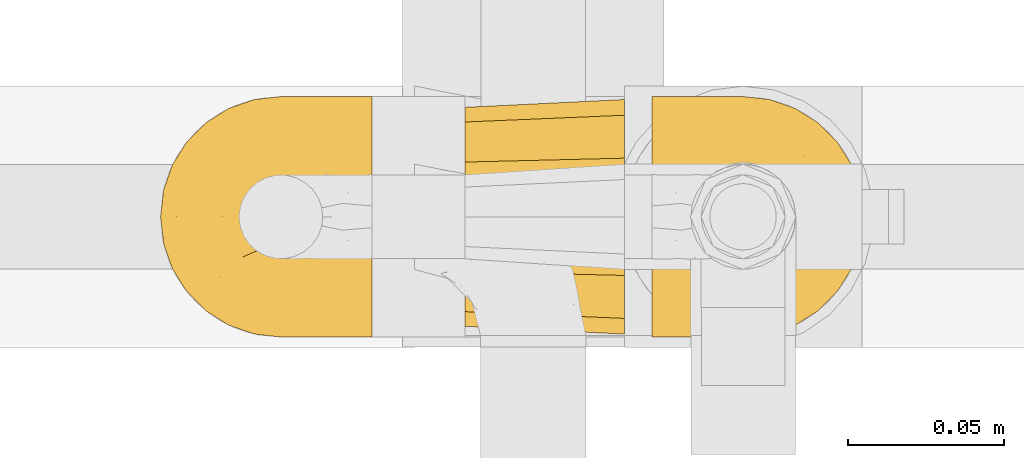
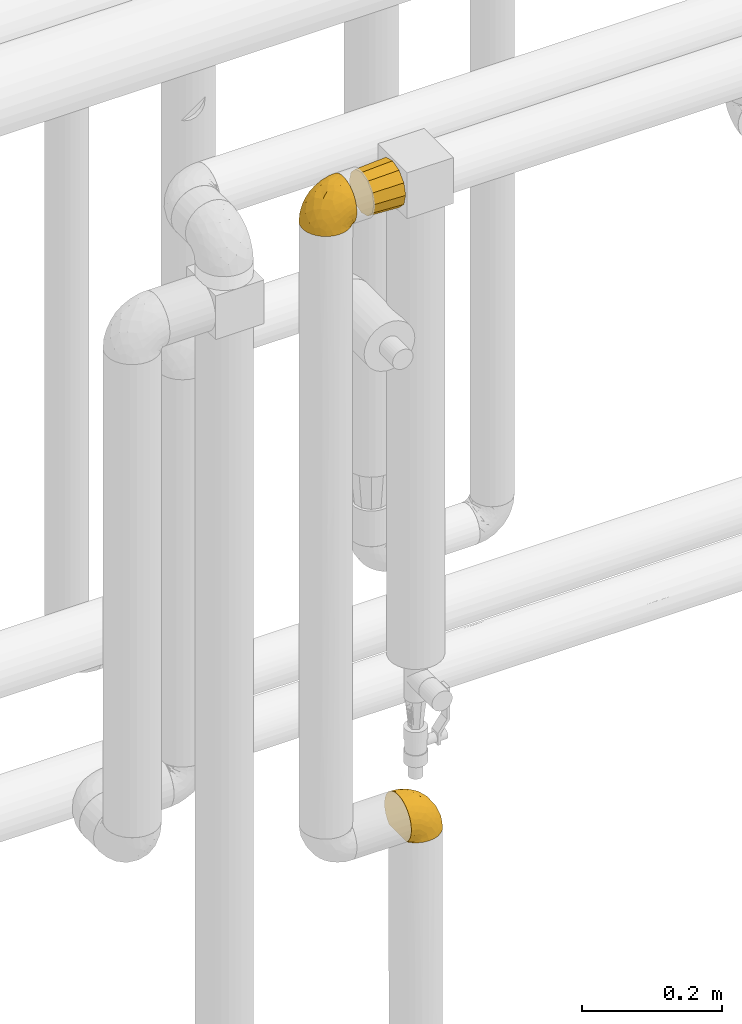
# One storey, part 442 of 827: 3 coverings.
"""IFC2X3 building model written with IfcOpenShell, lengths in millimetres."""

from ifc_helpers import new_model, entity, si_unit, converted_unit, derived_unit, direction, frame, origin, place, context, subcontext, project, spatial, faceted_brep, element, save


model = new_model("IFC2X3")

# Units and contexts
model_context = context("Model", 3, precision=0.01, world=origin(), true_north=direction((6.12303176911189e-17, 1.0)))
body_context = subcontext(model_context, "Body", "Model", "MODEL_VIEW")
ifc_project = project(units=[si_unit("LENGTHUNIT", "METRE", prefix="MILLI"), si_unit("AREAUNIT", "SQUARE_METRE"), si_unit("VOLUMEUNIT", "CUBIC_METRE"), converted_unit("PLANEANGLEUNIT", "DEGREE", entity("IfcRatioMeasure", 0.0174532925199433), si_unit("PLANEANGLEUNIT", "RADIAN"), dimensions=[0, 0, 0, 0, 0, 0, 0]), si_unit("MASSUNIT", "GRAM", prefix="KILO"), derived_unit("MASSDENSITYUNIT", [(si_unit("MASSUNIT", "GRAM", prefix="KILO"), 1), (si_unit("LENGTHUNIT", "METRE"), -3)]), derived_unit("MOMENTOFINERTIAUNIT", [(si_unit("LENGTHUNIT", "METRE"), 4)]), si_unit("TIMEUNIT", "SECOND"), si_unit("FREQUENCYUNIT", "HERTZ"), si_unit("THERMODYNAMICTEMPERATUREUNIT", "DEGREE_CELSIUS"), derived_unit("THERMALTRANSMITTANCEUNIT", [(si_unit("MASSUNIT", "GRAM", prefix="KILO"), 1), (si_unit("THERMODYNAMICTEMPERATUREUNIT", "KELVIN"), -1), (si_unit("TIMEUNIT", "SECOND"), -3)]), derived_unit("VOLUMETRICFLOWRATEUNIT", [(si_unit("LENGTHUNIT", "METRE"), 3), (si_unit("TIMEUNIT", "SECOND"), -1)]), derived_unit("MASSFLOWRATEUNIT", [(si_unit("MASSUNIT", "GRAM", prefix="KILO"), 1), (si_unit("TIMEUNIT", "SECOND"), -1)]), derived_unit("ROTATIONALFREQUENCYUNIT", [(si_unit("TIMEUNIT", "SECOND"), -1)]), si_unit("ELECTRICCURRENTUNIT", "AMPERE"), si_unit("ELECTRICVOLTAGEUNIT", "VOLT"), si_unit("POWERUNIT", "WATT"), si_unit("FORCEUNIT", "NEWTON", prefix="KILO"), si_unit("ILLUMINANCEUNIT", "LUX"), si_unit("LUMINOUSFLUXUNIT", "LUMEN"), si_unit("LUMINOUSINTENSITYUNIT", "CANDELA"), derived_unit("USERDEFINED", [(si_unit("MASSUNIT", "GRAM", prefix="KILO"), -1), (si_unit("LENGTHUNIT", "METRE"), -2), (si_unit("TIMEUNIT", "SECOND"), 3), (si_unit("LUMINOUSFLUXUNIT", "LUMEN"), 1)]), derived_unit("LINEARVELOCITYUNIT", [(si_unit("LENGTHUNIT", "METRE"), 1), (si_unit("TIMEUNIT", "SECOND"), -1)]), si_unit("PRESSUREUNIT", "PASCAL"), derived_unit("USERDEFINED", [(si_unit("LENGTHUNIT", "METRE"), -2), (si_unit("MASSUNIT", "GRAM", prefix="KILO"), 1), (si_unit("TIMEUNIT", "SECOND"), -2)]), derived_unit("LINEARFORCEUNIT", [(si_unit("MASSUNIT", "GRAM", prefix="KILO"), 1), (si_unit("LENGTHUNIT", "METRE"), 1), (si_unit("TIMEUNIT", "SECOND"), -2), (si_unit("LENGTHUNIT", "METRE"), -1)]), derived_unit("PLANARFORCEUNIT", [(si_unit("MASSUNIT", "GRAM", prefix="KILO"), 1), (si_unit("LENGTHUNIT", "METRE"), 1), (si_unit("TIMEUNIT", "SECOND"), -2), (si_unit("LENGTHUNIT", "METRE"), -2)])], contexts=[model_context])

# Site, building, storey
site_placement = place(None, origin())
site = spatial("IfcSite", under=ifc_project, at=site_placement, CompositionType="ELEMENT")
building_placement = place(site_placement, origin())
building = spatial("IfcBuilding", under=site, at=building_placement, CompositionType="ELEMENT")
storey_placement = place(building_placement, frame((0.0, 0.0, 28200.0)))
storey = spatial("IfcBuildingStorey", under=building, at=storey_placement, Name="08", CompositionType="ELEMENT", Elevation=28200.0)

# Coverings
covering_1_placement = place(storey_placement, frame((59152.59, 15404.16, 2669.3)))
element("IfcCovering", 1, at=covering_1_placement, inside=storey, Name=":ADSK_", ObjectType=":ADSK_", PredefinedType="INSULATION", context=body_context, shape_type="Brep", body=[
    faceted_brep([(23.36, 5.41, 1.6), (16.07, 9.99, 1.6), (9.98, 16.08, 1.6), (5.4, 23.37, 1.6), (2.56, 31.49, 1.6), (1.6, 40.05, 1.6), (2.56, 48.61, 1.6), (5.41, 56.73, 1.6), (9.99, 64.02, 1.6), (16.08, 70.11, 1.6), (23.37, 74.69, 1.6), (31.49, 77.53, 1.6), (40.05, 78.5, 1.6), (48.15, 77.63, 1.6), (55.88, 75.08, 1.6), (62.9, 70.97, 1.6), (68.89, 65.47, 1.6), (68.89, 63.27, 1.6), (68.89, 61.53, 1.6), (68.89, 59.57, 1.6), (68.89, 57.6, 1.6), (68.89, 55.63, 1.6), (68.89, 53.67, 1.6), (68.89, 51.7, 1.6), (68.89, 49.73, 1.6), (68.89, 47.54, 1.6), (68.89, 45.34, 1.6), (68.89, 43.15, 1.6), (68.89, 40.96, 1.6), (68.89, 38.76, 1.6), (68.89, 36.57, 1.6), (68.89, 34.37, 1.6), (68.89, 32.18, 1.6), (68.89, 29.98, 1.6), (68.89, 27.79, 1.6), (68.89, 25.6, 1.6), (68.89, 23.4, 1.6), (68.89, 21.21, 1.6), (68.89, 19.01, 1.6), (68.89, 16.82, 1.6), (68.89, 14.62, 1.6), (62.89, 9.12, 1.6), (55.86, 5.0, 1.6), (48.13, 2.46, 1.6), (40.05, 1.6, 1.6), (31.49, 2.56, 1.6), (69.15, 65.47, 1.85), (69.15, 70.97, 7.85), (69.15, 75.09, 14.87), (69.15, 77.63, 22.6), (69.15, 78.5, 30.7), (69.15, 77.19, 40.65), (69.15, 73.34, 49.92), (69.15, 67.23, 57.88), (69.15, 59.27, 63.99), (69.15, 50.0, 67.84), (69.15, 40.05, 69.15), (69.15, 30.09, 67.84), (69.15, 20.82, 63.99), (69.15, 12.86, 57.88), (69.15, 6.75, 49.92), (69.15, 2.91, 40.65), (69.15, 1.6, 30.7), (69.15, 2.46, 22.6), (69.15, 5.0, 14.87), (69.15, 9.12, 7.85), (69.15, 14.62, 1.85), (69.15, 16.82, 1.85), (69.15, 17.8, 1.85), (69.15, 19.39, 1.85), (69.15, 20.98, 1.85), (69.15, 22.57, 1.85), (69.15, 24.16, 1.85), (69.15, 25.75, 1.85), (69.15, 27.33, 1.85), (69.15, 28.92, 1.85), (69.15, 30.51, 1.85), (69.15, 32.1, 1.85), (69.15, 33.69, 1.85), (69.15, 35.28, 1.85), (69.15, 36.87, 1.85), (69.15, 38.46, 1.85), (69.15, 40.05, 1.85), (69.15, 41.63, 1.85), (69.15, 43.22, 1.85), (69.15, 44.81, 1.85), (69.15, 46.4, 1.85), (69.15, 47.99, 1.85), (69.15, 49.58, 1.85), (69.15, 51.17, 1.85), (69.15, 52.76, 1.85), (69.15, 54.72, 1.85), (69.15, 56.69, 1.85), (69.15, 58.88, 1.85), (69.15, 61.08, 1.85), (69.15, 63.27, 1.85), (68.96, 37.77, 1.77), (68.97, 36.07, 1.78), (68.97, 32.96, 1.77), (68.97, 31.36, 1.77), (68.95, 56.52, 1.76), (68.96, 54.96, 1.77), (68.98, 18.75, 1.79), (68.97, 58.07, 1.78), (68.97, 50.37, 1.78), (68.98, 23.36, 1.78), (68.97, 24.95, 1.78), (68.97, 42.43, 1.78), (68.94, 15.97, 1.74), (68.98, 51.96, 1.78), (68.98, 53.47, 1.78), (68.96, 48.63, 1.77), (68.97, 63.93, 1.78), (68.98, 40.93, 1.78), (68.98, 29.72, 1.78), (68.97, 62.4, 1.77), (68.96, 60.92, 1.77), (68.97, 17.31, 1.77), (68.97, 21.74, 1.78), (68.98, 34.56, 1.78), (68.96, 20.18, 1.77), (68.97, 14.62, 1.77), (68.94, 14.62, 1.72), (68.92, 14.62, 1.66), (68.97, 65.47, 1.77), (69.02, 65.47, 1.8), (69.08, 65.47, 1.82), (68.98, 59.5, 1.79), (68.97, 47.1, 1.78), (68.98, 45.61, 1.79), (68.97, 28.18, 1.78), (69.08, 14.62, 1.82), (69.02, 14.62, 1.8), (68.96, 26.61, 1.76), (68.92, 65.47, 1.66), (68.94, 65.47, 1.72), (68.97, 39.32, 1.78), (68.96, 44.12, 1.77), (67.02, 72.26, 9.41), (63.33, 76.57, 17.65), (64.61, 71.77, 7.41), (49.27, 78.5, 21.47), (51.4, 77.9, 15.21), (43.94, 78.5, 16.15), (61.87, 78.5, 28.75), (61.54, 75.52, 13.67), (57.95, 76.13, 12.79), (56.12, 77.81, 19.18), (63.4, 78.5, 29.16), (65.41, 72.4, 9.04), (53.1, 76.56, 7.41), (63.04, 71.77, 5.74), (61.33, 72.25, 3.72), (41.99, 78.5, 8.87), (54.6, 78.5, 26.8), (56.6, 75.75, 9.53), (41.58, 78.5, 7.34), (13.72, 50.46, 37.63), (5.82, 52.75, 17.92), (6.74, 40.05, 27.45), (58.82, 77.7, 37.01), (51.58, 77.66, 34.22), (42.09, 71.02, 45.87), (46.12, 63.45, 56.57), (55.56, 70.55, 52.31), (52.38, 75.57, 42.07), (61.54, 75.57, 44.74), (23.76, 72.61, 21.49), (20.5, 72.61, 11.02), (14.64, 67.24, 15.64), (41.77, 77.74, 26.02), (16.28, 57.43, 36.59), (49.4, 47.19, 65.49), (52.34, 54.76, 63.99), (4.3, 40.05, 15.2), (58.67, 63.45, 60.27), (25.26, 60.1, 45.25), (20.17, 63.72, 35.21), (34.7, 76.83, 22.52), (28.67, 76.34, 12.03), (8.62, 60.51, 13.32), (33.37, 72.59, 35.9), (41.35, 76.05, 33.87), (17.15, 66.15, 25.73), (12.68, 60.51, 26.34), (21.47, 51.88, 46.78), (41.11, 55.34, 59.54), (37.53, 48.67, 60.18), (30.64, 53.89, 53.93), (26.66, 46.73, 53.36), (21.38, 40.05, 49.36), (14.06, 40.05, 38.4), (55.54, 40.05, 66.44), (35.17, 63.95, 50.09), (29.04, 67.24, 41.08), (24.34, 69.62, 31.14), (29.33, 73.6, 28.19), (43.3, 40.05, 64.0), (32.34, 40.05, 56.68), (57.75, 4.52, 43.9), (49.41, 32.72, 65.46), (27.85, 27.18, 52.22), (13.7, 29.63, 37.61), (14.63, 12.86, 15.64), (8.61, 19.59, 13.31), (48.85, 9.54, 50.02), (54.13, 16.64, 59.28), (37.84, 17.48, 53.05), (23.75, 7.49, 21.48), (20.49, 7.49, 11.01), (28.66, 3.75, 12.03), (20.83, 20.75, 41.02), (55.15, 2.33, 35.39), (54.6, 1.6, 26.8), (61.87, 1.6, 28.75), (41.58, 1.6, 7.34), (57.58, 26.94, 65.81), (59.91, 9.54, 53.28), (36.94, 31.21, 59.8), (45.72, 25.33, 61.82), (5.82, 27.35, 17.91), (37.91, 8.17, 41.4), (50.18, 4.3, 40.48), (12.67, 19.59, 26.34), (49.29, 2.23, 31.68), (42.64, 2.45, 27.68), (43.94, 1.6, 16.15), (49.27, 1.6, 21.47), (19.45, 12.86, 28.05), (34.7, 3.27, 22.54), (41.99, 1.6, 8.87), (62.29, 2.29, 37.3), (29.01, 12.86, 41.07), (31.47, 6.89, 32.24), (37.18, 12.43, 47.4), (43.45, 4.1, 35.77), (63.33, 3.53, 17.65), (67.23, 6.88, 11.06), (66.07, 8.16, 8.55), (65.22, 9.02, 6.63), (61.99, 5.0, 12.77), (57.95, 3.96, 12.79), (53.09, 3.52, 7.41), (56.84, 2.4, 18.97), (61.33, 7.83, 3.72), (63.06, 8.32, 5.76), (51.41, 2.19, 15.21), (56.61, 4.34, 9.52)], [[[0, 1, 2, 3, 4, 5, 6, 7, 8, 9, 10, 11, 12, 13, 14, 15, 16, 17, 18, 19, 20, 21, 22, 23, 24, 25, 26, 27, 28, 29, 30, 31, 32, 33, 34, 35, 36, 37, 38, 39, 40, 41, 42, 43, 44, 45]], [[46, 47, 48, 49, 50, 51, 52, 53, 54, 55, 56, 57, 58, 59, 60, 61, 62, 63, 64, 65, 66, 67, 68, 69, 70, 71, 72, 73, 74, 75, 76, 77, 78, 79, 80, 81, 82, 83, 84, 85, 86, 87, 88, 89, 90, 91, 92, 93, 94, 95]], [[96, 97, 30]], [[98, 77, 99]], [[100, 101, 21]], [[69, 68, 102]], [[20, 19, 103]], [[24, 23, 104]], [[20, 103, 100]], [[72, 105, 106]], [[84, 83, 107]], [[89, 88, 104]], [[108, 67, 66]], [[109, 110, 90]], [[111, 25, 24]], [[112, 17, 16]], [[82, 113, 83]], [[109, 23, 22]], [[114, 76, 75]], [[105, 36, 106]], [[104, 111, 24]], [[18, 115, 116]], [[97, 96, 80]], [[67, 108, 117]], [[105, 71, 118]], [[31, 97, 119]], [[102, 120, 69]], [[108, 121, 122, 123, 40]], [[112, 95, 115]], [[17, 115, 18]], [[94, 116, 115]], [[117, 68, 67]], [[38, 117, 39]], [[112, 124, 125, 126, 46]], [[17, 112, 115]], [[70, 120, 118]], [[39, 117, 108]], [[120, 38, 37]], [[120, 37, 118]], [[120, 70, 69]], [[116, 94, 127]], [[128, 86, 129]], [[117, 38, 102]], [[74, 130, 75]], [[99, 33, 32]], [[115, 95, 94]], [[39, 108, 40]], [[108, 66, 131, 132, 121]], [[105, 72, 71]], [[118, 37, 36]], [[71, 70, 118]], [[35, 106, 36]], [[36, 105, 118]], [[35, 133, 106]], [[74, 73, 133]], [[106, 133, 73]], [[99, 114, 33]], [[133, 35, 34]], [[73, 72, 106]], [[95, 112, 46]], [[112, 16, 134, 135, 124]], [[130, 114, 75]], [[99, 76, 114]], [[114, 130, 33]], [[34, 33, 130]], [[78, 77, 98]], [[98, 119, 78]], [[130, 133, 34]], [[133, 130, 74]], [[79, 97, 80]], [[98, 99, 32]], [[98, 32, 31]], [[77, 76, 99]], [[97, 79, 119]], [[136, 96, 29]], [[30, 97, 31]], [[136, 29, 28]], [[81, 80, 96]], [[29, 96, 30]], [[31, 119, 98]], [[119, 79, 78]], [[96, 136, 81]], [[82, 81, 136]], [[113, 107, 83]], [[84, 107, 137]], [[107, 27, 137]], [[113, 28, 107]], [[27, 107, 28]], [[85, 84, 137]], [[137, 27, 26]], [[113, 136, 28]], [[136, 113, 82]], [[109, 89, 104]], [[86, 85, 129]], [[89, 109, 90]], [[111, 87, 128]], [[26, 129, 137]], [[88, 111, 104]], [[25, 111, 128]], [[22, 110, 109]], [[23, 109, 104]], [[110, 91, 90]], [[100, 92, 101]], [[110, 22, 101]], [[91, 110, 101]], [[116, 19, 18]], [[111, 88, 87]], [[127, 103, 19]], [[25, 128, 26]], [[86, 128, 87]], [[128, 129, 26]], [[137, 129, 85]], [[120, 102, 38]], [[117, 102, 68]], [[91, 101, 92]], [[21, 101, 22]], [[93, 92, 103]], [[100, 21, 20]], [[100, 103, 92]], [[127, 93, 103]], [[93, 127, 94]], [[116, 127, 19]], [[126, 138, 47]], [[48, 138, 139]], [[140, 125, 124]], [[141, 142, 143]], [[144, 49, 139]], [[145, 140, 146]], [[48, 139, 49]], [[139, 145, 147]], [[49, 144, 148, 50]], [[126, 125, 149]], [[14, 13, 150]], [[151, 146, 140]], [[149, 140, 145]], [[152, 151, 135]], [[152, 14, 150]], [[16, 15, 134]], [[13, 153, 150]], [[124, 151, 140]], [[141, 147, 142]], [[14, 152, 15]], [[15, 152, 134]], [[47, 46, 126]], [[139, 154, 144]], [[138, 48, 47]], [[125, 140, 149]], [[135, 134, 152]], [[146, 155, 142]], [[145, 146, 147]], [[149, 139, 138]], [[147, 141, 154]], [[147, 146, 142]], [[139, 147, 154]], [[139, 149, 145]], [[149, 138, 126]], [[155, 146, 151]], [[150, 143, 142]], [[152, 155, 151]], [[150, 142, 155]], [[13, 12, 156, 153]], [[153, 143, 150]], [[152, 150, 155]], [[151, 124, 135]], [[157, 158, 159]], [[160, 154, 161]], [[162, 163, 164]], [[165, 166, 160]], [[167, 168, 169]], [[141, 170, 161]], [[156, 12, 11]], [[158, 157, 171]], [[172, 55, 173]], [[158, 6, 174]], [[175, 54, 53]], [[52, 166, 164]], [[52, 164, 53]], [[54, 175, 173]], [[166, 52, 51]], [[176, 177, 171]], [[178, 143, 179]], [[156, 11, 179]], [[8, 7, 180]], [[169, 9, 8]], [[179, 143, 153, 156]], [[179, 11, 10]], [[168, 179, 10]], [[181, 162, 182]], [[179, 167, 178]], [[183, 184, 177]], [[183, 169, 184]], [[176, 171, 185]], [[172, 186, 187]], [[158, 7, 6]], [[159, 158, 174]], [[184, 180, 158]], [[54, 173, 55]], [[180, 169, 8]], [[188, 189, 187]], [[9, 168, 10]], [[186, 188, 187]], [[190, 157, 159, 191]], [[55, 172, 192]], [[176, 193, 194]], [[161, 170, 182]], [[162, 164, 165]], [[175, 164, 163]], [[51, 50, 148]], [[167, 195, 196]], [[178, 182, 170]], [[6, 5, 174]], [[158, 180, 7]], [[169, 180, 184]], [[169, 168, 9]], [[179, 168, 167]], [[182, 162, 165]], [[162, 194, 193]], [[161, 165, 160]], [[195, 181, 196]], [[192, 172, 197]], [[192, 56, 55]], [[189, 190, 198]], [[198, 197, 187]], [[172, 187, 197]], [[185, 189, 188]], [[198, 187, 189]], [[186, 172, 173]], [[173, 163, 186]], [[193, 186, 163]], [[176, 185, 188]], [[185, 157, 190]], [[188, 186, 193]], [[177, 176, 194]], [[188, 193, 176]], [[162, 193, 163]], [[195, 177, 194]], [[171, 177, 184]], [[181, 195, 194]], [[183, 167, 169]], [[162, 181, 194]], [[196, 182, 178]], [[158, 171, 184]], [[171, 157, 185]], [[177, 195, 183]], [[167, 183, 195]], [[182, 196, 181]], [[178, 170, 143]], [[178, 167, 196]], [[164, 175, 53]], [[173, 175, 163]], [[160, 51, 148]], [[164, 166, 165]], [[51, 160, 166]], [[160, 148, 144, 154]], [[141, 161, 154]], [[182, 165, 161]], [[190, 189, 185]], [[143, 170, 141]], [[60, 199, 61]], [[197, 200, 192]], [[201, 190, 202]], [[200, 57, 192]], [[203, 204, 2]], [[205, 206, 207]], [[208, 209, 210]], [[211, 207, 201]], [[212, 213, 214]], [[45, 215, 210]], [[216, 206, 58]], [[45, 44, 215]], [[59, 217, 60]], [[60, 217, 199]], [[0, 45, 210]], [[218, 201, 219]], [[202, 159, 220]], [[205, 221, 222]], [[223, 204, 203]], [[1, 203, 2]], [[57, 200, 216]], [[220, 3, 204]], [[220, 174, 4]], [[1, 0, 209]], [[212, 224, 213]], [[225, 226, 227]], [[228, 223, 203]], [[208, 210, 229]], [[210, 226, 229]], [[3, 220, 4]], [[58, 206, 59]], [[209, 203, 1]], [[202, 220, 223]], [[228, 203, 208]], [[202, 211, 201]], [[3, 2, 204]], [[202, 190, 191, 159]], [[210, 215, 230, 226]], [[199, 212, 231]], [[232, 233, 221]], [[233, 208, 229]], [[207, 206, 219]], [[217, 206, 205]], [[227, 224, 225]], [[233, 232, 228]], [[201, 207, 219]], [[234, 232, 221]], [[218, 219, 200]], [[202, 223, 211]], [[174, 220, 159]], [[174, 5, 4]], [[61, 231, 62]], [[220, 204, 223]], [[210, 209, 0]], [[203, 209, 208]], [[225, 233, 229]], [[224, 227, 213]], [[221, 233, 235]], [[57, 56, 192]], [[198, 218, 197]], [[200, 219, 216]], [[201, 198, 190]], [[197, 218, 200]], [[198, 201, 218]], [[206, 216, 219]], [[58, 57, 216]], [[231, 212, 214]], [[222, 212, 199]], [[228, 211, 223]], [[207, 211, 232]], [[62, 231, 214]], [[199, 231, 61]], [[233, 228, 208]], [[211, 228, 232]], [[222, 221, 235]], [[234, 205, 207]], [[206, 217, 59]], [[199, 217, 205]], [[205, 222, 199]], [[224, 222, 235]], [[222, 224, 212]], [[224, 235, 225]], [[233, 225, 235]], [[226, 225, 229]], [[205, 234, 221]], [[207, 232, 234]], [[63, 214, 236]], [[214, 213, 236]], [[214, 63, 62]], [[237, 236, 238]], [[238, 132, 131]], [[236, 237, 64]], [[239, 240, 241]], [[63, 236, 64]], [[131, 66, 65]], [[237, 131, 65]], [[242, 230, 43]], [[237, 65, 64]], [[239, 121, 132]], [[42, 242, 43]], [[241, 240, 243]], [[41, 123, 244]], [[43, 230, 215, 44]], [[244, 122, 245]], [[227, 246, 243]], [[241, 247, 245]], [[121, 239, 245]], [[41, 40, 123]], [[132, 238, 239]], [[244, 42, 41]], [[131, 237, 238]], [[240, 239, 238]], [[245, 239, 241]], [[247, 241, 246]], [[247, 244, 245]], [[238, 236, 240]], [[243, 236, 213]], [[236, 243, 240]], [[227, 226, 246]], [[243, 213, 227]], [[242, 246, 226]], [[243, 246, 241]], [[246, 242, 247]], [[244, 247, 242]], [[242, 226, 230]], [[42, 244, 242]], [[122, 244, 123]], [[122, 121, 245]]]),
])
covering_2_placement = place(storey_placement, frame((59309.77, 15404.16, 1562.35)))
element("IfcCovering", 2, at=covering_2_placement, inside=storey, Name=":ADSK_", ObjectType=":ADSK_", PredefinedType="INSULATION", context=body_context, shape_type="Brep", body=[
    faceted_brep([(47.38, 74.68, 1.6), (54.67, 70.1, 1.6), (60.76, 64.01, 1.6), (65.34, 56.72, 1.6), (68.18, 48.6, 1.6), (69.15, 40.05, 1.6), (68.18, 31.49, 1.6), (65.33, 23.36, 1.6), (60.75, 16.07, 1.6), (54.66, 9.98, 1.6), (47.37, 5.4, 1.6), (39.25, 2.56, 1.6), (30.7, 1.6, 1.6), (22.59, 2.46, 1.6), (14.86, 5.01, 1.6), (7.84, 9.13, 1.6), (1.85, 14.62, 1.6), (1.85, 16.82, 1.6), (1.85, 18.56, 1.6), (1.85, 20.52, 1.6), (1.85, 22.49, 1.6), (1.85, 24.46, 1.6), (1.85, 26.42, 1.6), (1.85, 28.39, 1.6), (1.85, 30.36, 1.6), (1.85, 32.55, 1.6), (1.85, 34.75, 1.6), (1.85, 36.94, 1.6), (1.85, 39.13, 1.6), (1.85, 41.33, 1.6), (1.85, 43.52, 1.6), (1.85, 45.72, 1.6), (1.85, 47.91, 1.6), (1.85, 50.11, 1.6), (1.85, 52.3, 1.6), (1.85, 54.49, 1.6), (1.85, 56.69, 1.6), (1.85, 58.88, 1.6), (1.85, 61.08, 1.6), (1.85, 63.27, 1.6), (1.85, 65.47, 1.6), (7.85, 70.97, 1.6), (14.88, 75.09, 1.6), (22.61, 77.64, 1.6), (30.7, 78.5, 1.6), (39.26, 77.53, 1.6), (1.6, 14.62, 1.85), (1.6, 9.12, 7.85), (1.6, 5.0, 14.87), (1.6, 2.46, 22.6), (1.6, 1.6, 30.7), (1.6, 2.91, 40.65), (1.6, 6.75, 49.92), (1.6, 12.86, 57.88), (1.6, 20.82, 63.99), (1.6, 30.09, 67.84), (1.6, 40.05, 69.15), (1.6, 50.0, 67.84), (1.6, 59.27, 63.99), (1.6, 67.23, 57.88), (1.6, 73.34, 49.92), (1.6, 77.19, 40.65), (1.6, 78.5, 30.7), (1.6, 77.63, 22.6), (1.6, 75.09, 14.87), (1.6, 70.97, 7.85), (1.6, 65.47, 1.85), (1.6, 63.27, 1.85), (1.6, 62.29, 1.85), (1.6, 60.7, 1.85), (1.6, 59.11, 1.85), (1.6, 57.52, 1.85), (1.6, 55.93, 1.85), (1.6, 54.34, 1.85), (1.6, 52.76, 1.85), (1.6, 51.17, 1.85), (1.6, 49.58, 1.85), (1.6, 47.99, 1.85), (1.6, 46.4, 1.85), (1.6, 44.81, 1.85), (1.6, 43.22, 1.85), (1.6, 41.63, 1.85), (1.6, 40.05, 1.85), (1.6, 38.46, 1.85), (1.6, 36.87, 1.85), (1.6, 35.28, 1.85), (1.6, 33.69, 1.85), (1.6, 32.1, 1.85), (1.6, 30.51, 1.85), (1.6, 28.92, 1.85), (1.6, 27.33, 1.85), (1.6, 25.37, 1.85), (1.6, 23.4, 1.85), (1.6, 21.21, 1.85), (1.6, 19.01, 1.85), (1.6, 16.82, 1.85), (1.78, 42.32, 1.77), (1.77, 44.02, 1.78), (1.78, 47.13, 1.77), (1.77, 48.74, 1.77), (1.79, 23.57, 1.76), (1.78, 25.13, 1.77), (1.76, 61.34, 1.79), (1.77, 22.02, 1.78), (1.77, 29.72, 1.78), (1.76, 56.73, 1.78), (1.77, 55.14, 1.78), (1.77, 37.66, 1.78), (1.8, 64.12, 1.74), (1.76, 28.13, 1.78), (1.77, 26.62, 1.78), (1.78, 31.46, 1.77), (1.77, 16.16, 1.78), (1.77, 39.16, 1.78), (1.76, 50.37, 1.78), (1.77, 17.69, 1.77), (1.78, 19.17, 1.77), (1.77, 62.78, 1.77), (1.77, 58.35, 1.78), (1.77, 45.53, 1.78), (1.78, 59.91, 1.77), (1.77, 65.47, 1.77), (1.8, 65.47, 1.72), (1.82, 65.47, 1.66), (1.77, 14.62, 1.77), (1.72, 14.62, 1.8), (1.66, 14.62, 1.82), (1.76, 20.59, 1.79), (1.77, 32.99, 1.78), (1.76, 34.48, 1.79), (1.77, 51.91, 1.78), (1.66, 65.47, 1.82), (1.72, 65.47, 1.8), (1.78, 53.48, 1.76), (1.82, 14.62, 1.66), (1.8, 14.62, 1.72), (1.77, 40.77, 1.78), (1.78, 35.97, 1.77), (3.72, 7.84, 9.41), (7.41, 3.53, 17.65), (6.13, 8.32, 7.41), (21.47, 1.6, 21.47), (19.34, 2.19, 15.21), (26.8, 1.6, 16.15), (8.87, 1.6, 28.75), (9.2, 4.57, 13.67), (12.79, 3.96, 12.79), (14.62, 2.28, 19.18), (7.34, 1.6, 29.16), (5.33, 7.69, 9.04), (17.64, 3.53, 7.41), (7.7, 8.32, 5.74), (9.41, 7.84, 3.72), (28.75, 1.6, 8.87), (16.15, 1.6, 26.8), (14.14, 4.34, 9.53), (29.16, 1.6, 7.34), (57.02, 29.63, 37.63), (64.92, 27.34, 17.92), (64.0, 40.05, 27.45), (11.92, 2.39, 37.01), (19.16, 2.43, 34.22), (28.65, 9.07, 45.87), (24.62, 16.64, 56.57), (15.19, 9.54, 52.31), (18.36, 4.52, 42.07), (9.2, 4.52, 44.74), (46.98, 7.49, 21.49), (50.24, 7.49, 11.02), (56.1, 12.85, 15.64), (28.97, 2.35, 26.02), (54.46, 22.66, 36.59), (21.34, 32.9, 65.49), (18.4, 25.33, 63.99), (66.44, 40.05, 15.2), (12.07, 16.64, 60.27), (45.49, 19.99, 45.25), (50.57, 16.37, 35.21), (36.04, 3.26, 22.52), (42.07, 3.75, 12.03), (62.12, 19.58, 13.32), (37.37, 7.5, 35.9), (29.39, 4.04, 33.87), (53.59, 13.94, 25.73), (58.06, 19.58, 26.34), (49.27, 28.21, 46.78), (29.63, 24.75, 59.54), (33.21, 31.42, 60.18), (40.1, 26.2, 53.93), (44.08, 33.36, 53.36), (49.36, 40.05, 49.36), (56.68, 40.05, 38.4), (15.2, 40.05, 66.44), (35.57, 16.14, 50.09), (41.7, 12.85, 41.08), (46.4, 10.47, 31.14), (41.41, 6.49, 28.19), (27.45, 40.05, 64.0), (38.4, 40.05, 56.68), (12.99, 75.57, 43.9), (21.33, 47.37, 65.46), (42.89, 52.91, 52.22), (57.04, 50.46, 37.61), (56.11, 67.23, 15.64), (62.13, 60.5, 13.31), (21.89, 70.55, 50.02), (16.62, 63.45, 59.28), (32.9, 62.61, 53.05), (46.99, 72.6, 21.48), (50.25, 72.6, 11.01), (42.08, 76.34, 12.03), (49.91, 59.34, 41.02), (15.6, 77.76, 35.39), (16.15, 78.5, 26.8), (8.87, 78.5, 28.75), (29.16, 78.5, 7.34), (13.16, 53.16, 65.81), (10.83, 70.55, 53.28), (33.8, 48.88, 59.8), (25.02, 54.76, 61.82), (64.92, 52.74, 17.91), (32.83, 71.93, 41.4), (20.56, 75.79, 40.48), (58.07, 60.5, 26.34), (21.46, 77.86, 31.68), (28.1, 77.64, 27.68), (26.8, 78.5, 16.15), (21.47, 78.5, 21.47), (51.29, 67.23, 28.05), (36.04, 76.82, 22.54), (28.75, 78.5, 8.87), (8.45, 77.8, 37.3), (41.73, 67.23, 41.07), (39.27, 73.2, 32.24), (33.56, 67.66, 47.4), (27.29, 75.99, 35.77), (7.41, 76.57, 17.65), (3.51, 73.21, 11.06), (4.68, 71.93, 8.55), (5.52, 71.07, 6.63), (8.75, 75.09, 12.77), (12.79, 76.13, 12.79), (17.65, 76.57, 7.41), (13.9, 77.69, 18.97), (9.42, 72.26, 3.72), (7.68, 71.77, 5.76), (19.33, 77.9, 15.21), (14.13, 75.75, 9.52)], [[[0, 1, 2, 3, 4, 5, 6, 7, 8, 9, 10, 11, 12, 13, 14, 15, 16, 17, 18, 19, 20, 21, 22, 23, 24, 25, 26, 27, 28, 29, 30, 31, 32, 33, 34, 35, 36, 37, 38, 39, 40, 41, 42, 43, 44, 45]], [[46, 47, 48, 49, 50, 51, 52, 53, 54, 55, 56, 57, 58, 59, 60, 61, 62, 63, 64, 65, 66, 67, 68, 69, 70, 71, 72, 73, 74, 75, 76, 77, 78, 79, 80, 81, 82, 83, 84, 85, 86, 87, 88, 89, 90, 91, 92, 93, 94, 95]], [[96, 97, 30]], [[98, 77, 99]], [[100, 101, 21]], [[69, 68, 102]], [[20, 19, 103]], [[24, 23, 104]], [[20, 103, 100]], [[72, 105, 106]], [[84, 83, 107]], [[89, 88, 104]], [[108, 67, 66]], [[109, 110, 90]], [[111, 25, 24]], [[112, 17, 16]], [[82, 113, 83]], [[109, 23, 22]], [[114, 76, 75]], [[105, 36, 106]], [[104, 111, 24]], [[18, 115, 116]], [[97, 96, 80]], [[67, 108, 117]], [[105, 71, 118]], [[31, 97, 119]], [[102, 120, 69]], [[108, 121, 122, 123, 40]], [[112, 95, 115]], [[17, 115, 18]], [[94, 116, 115]], [[117, 68, 67]], [[38, 117, 39]], [[112, 124, 125, 126, 46]], [[17, 112, 115]], [[70, 120, 118]], [[39, 117, 108]], [[120, 38, 37]], [[120, 37, 118]], [[120, 70, 69]], [[116, 94, 127]], [[128, 86, 129]], [[117, 38, 102]], [[74, 130, 75]], [[99, 33, 32]], [[115, 95, 94]], [[39, 108, 40]], [[108, 66, 131, 132, 121]], [[105, 72, 71]], [[118, 37, 36]], [[71, 70, 118]], [[35, 106, 36]], [[36, 105, 118]], [[35, 133, 106]], [[74, 73, 133]], [[106, 133, 73]], [[99, 114, 33]], [[133, 35, 34]], [[73, 72, 106]], [[95, 112, 46]], [[112, 16, 134, 135, 124]], [[130, 114, 75]], [[99, 76, 114]], [[114, 130, 33]], [[34, 33, 130]], [[78, 77, 98]], [[98, 119, 78]], [[130, 133, 34]], [[133, 130, 74]], [[79, 97, 80]], [[98, 99, 32]], [[98, 32, 31]], [[77, 76, 99]], [[97, 79, 119]], [[136, 96, 29]], [[30, 97, 31]], [[136, 29, 28]], [[81, 80, 96]], [[29, 96, 30]], [[31, 119, 98]], [[119, 79, 78]], [[96, 136, 81]], [[82, 81, 136]], [[113, 107, 83]], [[84, 107, 137]], [[107, 27, 137]], [[113, 28, 107]], [[27, 107, 28]], [[85, 84, 137]], [[137, 27, 26]], [[113, 136, 28]], [[136, 113, 82]], [[109, 89, 104]], [[86, 85, 129]], [[89, 109, 90]], [[111, 87, 128]], [[26, 129, 137]], [[88, 111, 104]], [[25, 111, 128]], [[22, 110, 109]], [[23, 109, 104]], [[110, 91, 90]], [[100, 92, 101]], [[110, 22, 101]], [[91, 110, 101]], [[116, 19, 18]], [[111, 88, 87]], [[127, 103, 19]], [[25, 128, 26]], [[86, 128, 87]], [[128, 129, 26]], [[137, 129, 85]], [[120, 102, 38]], [[117, 102, 68]], [[91, 101, 92]], [[21, 101, 22]], [[93, 92, 103]], [[100, 21, 20]], [[100, 103, 92]], [[127, 93, 103]], [[93, 127, 94]], [[116, 127, 19]], [[126, 138, 47]], [[48, 138, 139]], [[140, 125, 124]], [[141, 142, 143]], [[144, 49, 139]], [[145, 140, 146]], [[48, 139, 49]], [[139, 145, 147]], [[49, 144, 148, 50]], [[126, 125, 149]], [[14, 13, 150]], [[151, 146, 140]], [[149, 140, 145]], [[152, 151, 135]], [[152, 14, 150]], [[16, 15, 134]], [[13, 153, 150]], [[124, 151, 140]], [[141, 147, 142]], [[14, 152, 15]], [[15, 152, 134]], [[47, 46, 126]], [[139, 154, 144]], [[138, 48, 47]], [[125, 140, 149]], [[135, 134, 152]], [[146, 155, 142]], [[145, 146, 147]], [[149, 139, 138]], [[147, 141, 154]], [[147, 146, 142]], [[139, 147, 154]], [[139, 149, 145]], [[149, 138, 126]], [[155, 146, 151]], [[150, 143, 142]], [[152, 155, 151]], [[150, 142, 155]], [[13, 12, 156, 153]], [[153, 143, 150]], [[152, 150, 155]], [[151, 124, 135]], [[157, 158, 159]], [[160, 154, 161]], [[162, 163, 164]], [[165, 166, 160]], [[167, 168, 169]], [[141, 170, 161]], [[156, 12, 11]], [[158, 157, 171]], [[172, 55, 173]], [[158, 6, 174]], [[175, 54, 53]], [[52, 166, 164]], [[52, 164, 53]], [[54, 175, 173]], [[166, 52, 51]], [[176, 177, 171]], [[178, 143, 179]], [[156, 11, 179]], [[8, 7, 180]], [[169, 9, 8]], [[179, 143, 153, 156]], [[179, 11, 10]], [[168, 179, 10]], [[181, 162, 182]], [[179, 167, 178]], [[183, 184, 177]], [[183, 169, 184]], [[176, 171, 185]], [[172, 186, 187]], [[158, 7, 6]], [[159, 158, 174]], [[184, 180, 158]], [[54, 173, 55]], [[180, 169, 8]], [[188, 189, 187]], [[9, 168, 10]], [[186, 188, 187]], [[190, 157, 159, 191]], [[55, 172, 192]], [[176, 193, 194]], [[161, 170, 182]], [[162, 164, 165]], [[175, 164, 163]], [[51, 50, 148]], [[167, 195, 196]], [[178, 182, 170]], [[6, 5, 174]], [[158, 180, 7]], [[169, 180, 184]], [[169, 168, 9]], [[179, 168, 167]], [[182, 162, 165]], [[162, 194, 193]], [[161, 165, 160]], [[195, 181, 196]], [[192, 172, 197]], [[192, 56, 55]], [[189, 190, 198]], [[198, 197, 187]], [[172, 187, 197]], [[185, 189, 188]], [[198, 187, 189]], [[186, 172, 173]], [[173, 163, 186]], [[193, 186, 163]], [[176, 185, 188]], [[185, 157, 190]], [[188, 186, 193]], [[177, 176, 194]], [[188, 193, 176]], [[162, 193, 163]], [[195, 177, 194]], [[171, 177, 184]], [[181, 195, 194]], [[183, 167, 169]], [[162, 181, 194]], [[196, 182, 178]], [[158, 171, 184]], [[171, 157, 185]], [[177, 195, 183]], [[167, 183, 195]], [[182, 196, 181]], [[178, 170, 143]], [[178, 167, 196]], [[164, 175, 53]], [[173, 175, 163]], [[160, 51, 148]], [[164, 166, 165]], [[51, 160, 166]], [[160, 148, 144, 154]], [[141, 161, 154]], [[182, 165, 161]], [[190, 189, 185]], [[143, 170, 141]], [[60, 199, 61]], [[197, 200, 192]], [[201, 190, 202]], [[200, 57, 192]], [[203, 204, 2]], [[205, 206, 207]], [[208, 209, 210]], [[211, 207, 201]], [[212, 213, 214]], [[45, 215, 210]], [[216, 206, 58]], [[45, 44, 215]], [[59, 217, 60]], [[60, 217, 199]], [[0, 45, 210]], [[218, 201, 219]], [[202, 159, 220]], [[205, 221, 222]], [[223, 204, 203]], [[1, 203, 2]], [[57, 200, 216]], [[220, 3, 204]], [[220, 174, 4]], [[1, 0, 209]], [[212, 224, 213]], [[225, 226, 227]], [[228, 223, 203]], [[208, 210, 229]], [[210, 226, 229]], [[3, 220, 4]], [[58, 206, 59]], [[209, 203, 1]], [[202, 220, 223]], [[228, 203, 208]], [[202, 211, 201]], [[3, 2, 204]], [[202, 190, 191, 159]], [[210, 215, 230, 226]], [[199, 212, 231]], [[232, 233, 221]], [[233, 208, 229]], [[207, 206, 219]], [[217, 206, 205]], [[227, 224, 225]], [[233, 232, 228]], [[201, 207, 219]], [[234, 232, 221]], [[218, 219, 200]], [[202, 223, 211]], [[174, 220, 159]], [[174, 5, 4]], [[61, 231, 62]], [[220, 204, 223]], [[210, 209, 0]], [[203, 209, 208]], [[225, 233, 229]], [[224, 227, 213]], [[221, 233, 235]], [[57, 56, 192]], [[198, 218, 197]], [[200, 219, 216]], [[201, 198, 190]], [[197, 218, 200]], [[198, 201, 218]], [[206, 216, 219]], [[58, 57, 216]], [[231, 212, 214]], [[222, 212, 199]], [[228, 211, 223]], [[207, 211, 232]], [[62, 231, 214]], [[199, 231, 61]], [[233, 228, 208]], [[211, 228, 232]], [[222, 221, 235]], [[234, 205, 207]], [[206, 217, 59]], [[199, 217, 205]], [[205, 222, 199]], [[224, 222, 235]], [[222, 224, 212]], [[224, 235, 225]], [[233, 225, 235]], [[226, 225, 229]], [[205, 234, 221]], [[207, 232, 234]], [[63, 214, 236]], [[214, 213, 236]], [[214, 63, 62]], [[237, 236, 238]], [[238, 132, 131]], [[236, 237, 64]], [[239, 240, 241]], [[63, 236, 64]], [[131, 66, 65]], [[237, 131, 65]], [[242, 230, 43]], [[237, 65, 64]], [[239, 121, 132]], [[42, 242, 43]], [[241, 240, 243]], [[41, 123, 244]], [[43, 230, 215, 44]], [[244, 122, 245]], [[227, 246, 243]], [[241, 247, 245]], [[121, 239, 245]], [[41, 40, 123]], [[132, 238, 239]], [[244, 42, 41]], [[131, 237, 238]], [[240, 239, 238]], [[245, 239, 241]], [[247, 241, 246]], [[247, 244, 245]], [[238, 236, 240]], [[243, 236, 213]], [[236, 243, 240]], [[227, 226, 246]], [[243, 213, 227]], [[242, 246, 226]], [[243, 246, 241]], [[246, 242, 247]], [[244, 247, 242]], [[242, 226, 230]], [[42, 244, 242]], [[122, 244, 123]], [[122, 121, 245]]]),
])
covering_3_placement = place(storey_placement, frame((59251.46, 15405.11, 2660.9)))
element("IfcCovering", 3, at=covering_3_placement, inside=storey, Name=":ADSK_", ObjectType=":ADSK_", PredefinedType="INSULATION", context=body_context, shape_type="Brep", body=[
    faceted_brep([(0.0, 74.1, 39.1), (0.0, 71.75, 30.35), (0.0, 69.41, 21.6), (0.0, 63.0, 15.19), (0.0, 56.6, 8.78), (0.0, 47.85, 6.44), (0.0, 39.1, 4.1), (0.0, 30.35, 6.44), (0.0, 21.6, 8.78), (0.0, 15.19, 15.19), (0.0, 8.78, 21.6), (0.0, 6.44, 30.35), (0.0, 4.1, 39.1), (0.0, 6.44, 47.85), (0.0, 8.78, 56.6), (0.0, 15.19, 63.0), (0.0, 21.6, 69.41), (0.0, 30.35, 71.75), (0.0, 39.1, 74.1), (0.0, 47.85, 71.75), (0.0, 56.6, 69.41), (0.0, 63.0, 63.0), (0.0, 69.41, 56.6), (0.0, 71.75, 47.85), (51.0, 20.35, 71.57), (51.0, 13.48, 64.71), (51.0, 6.62, 57.85), (51.0, 5.04, 51.96), (51.0, 3.32, 45.53), (51.0, 1.6, 39.1), (51.0, 3.32, 32.66), (51.0, 5.04, 26.23), (51.0, 6.62, 20.35), (51.0, 13.48, 13.48), (51.0, 20.35, 6.62), (51.0, 26.23, 5.04), (51.0, 32.66, 3.32), (51.0, 39.1, 1.6), (51.0, 45.53, 3.32), (51.0, 51.96, 5.04), (51.0, 57.85, 6.62), (51.0, 64.71, 13.48), (51.0, 71.57, 20.35), (51.0, 73.15, 26.23), (51.0, 74.87, 32.66), (51.0, 76.6, 39.1), (51.0, 74.87, 45.53), (51.0, 73.15, 51.96), (51.0, 71.57, 57.85), (51.0, 64.71, 64.71), (51.0, 57.85, 71.57), (51.0, 51.96, 73.15), (51.0, 45.53, 74.87), (51.0, 39.1, 76.6), (51.0, 32.66, 74.87), (51.0, 26.23, 73.15)], [[[0, 1, 2, 3, 4, 5, 6, 7, 8, 9, 10, 11, 12, 13, 14, 15, 16, 17, 18, 19, 20, 21, 22, 23]], [[24, 25, 26, 27, 28, 29, 30, 31, 32, 33, 34, 35, 36, 37, 38, 39, 40, 41, 42, 43, 44, 45, 46, 47, 48, 49, 50, 51, 52, 53, 54, 55]], [[4, 40, 39, 38, 37, 6, 5]], [[42, 41, 40, 4, 3, 2]], [[45, 44, 43, 42, 2, 1, 0]], [[10, 32, 31, 30, 29, 12, 11]], [[34, 33, 32, 10, 9, 8]], [[37, 36, 35, 34, 8, 7, 6]], [[16, 24, 55, 54, 53, 18, 17]], [[26, 25, 24, 16, 15, 14]], [[29, 28, 27, 26, 14, 13, 12]], [[22, 48, 47, 46, 45, 0, 23]], [[50, 49, 48, 22, 21, 20]], [[53, 52, 51, 50, 20, 19, 18]]]),
])

save(model, "model.ifc")
